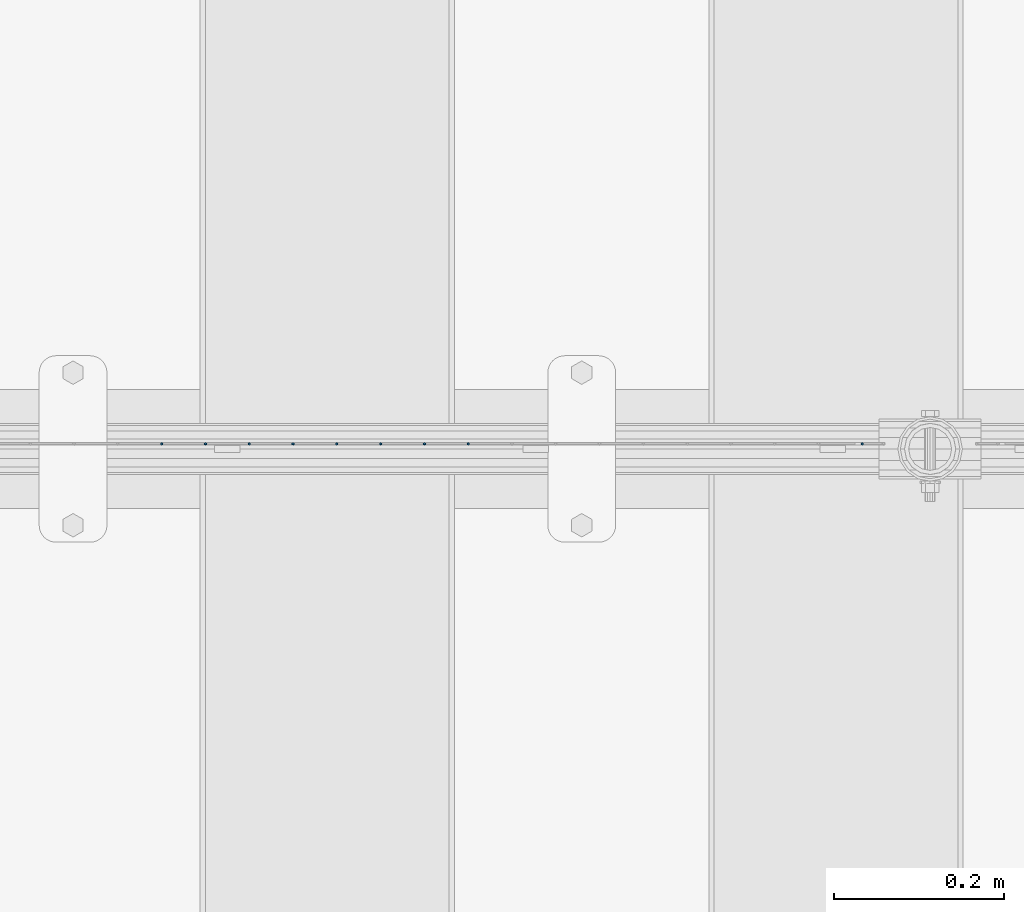
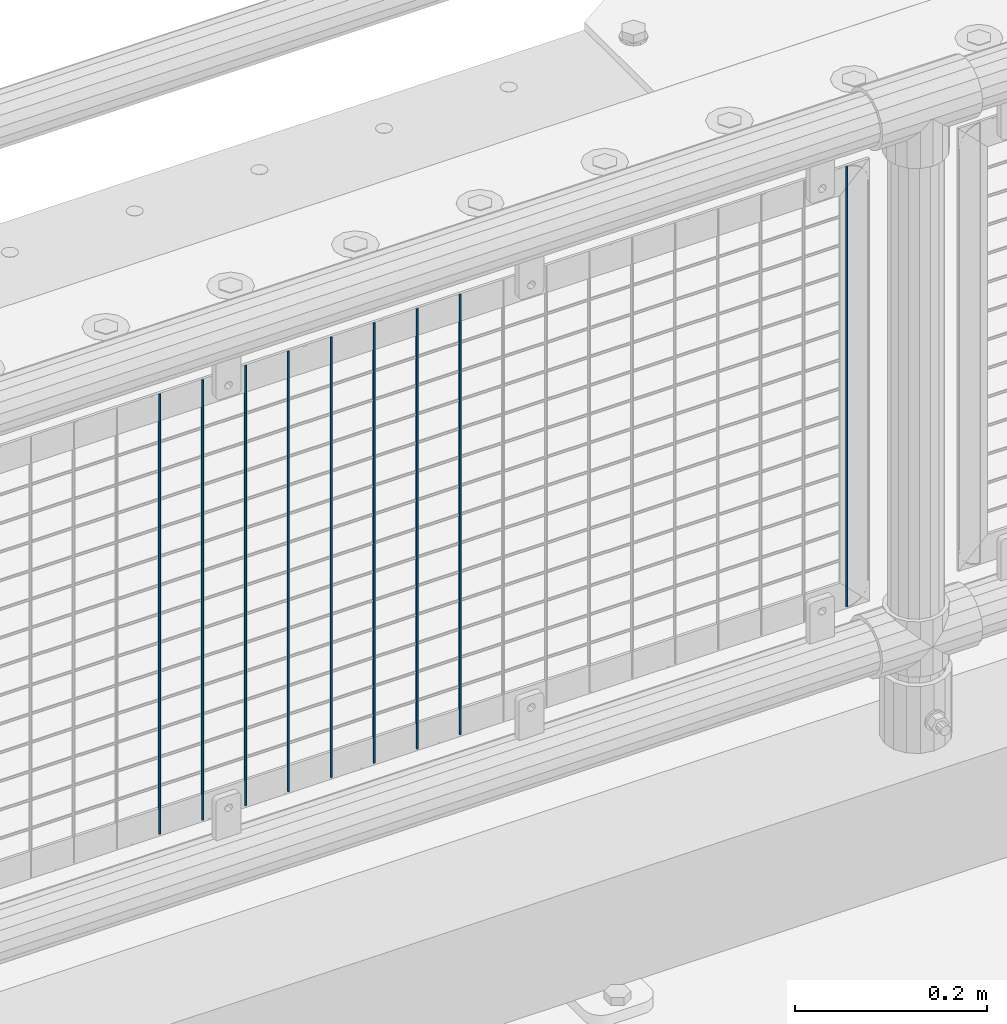
# One storey, part 71 of 193: 9 columns.
"""IFC2X3 building model written with IfcOpenShell, lengths in millimetres."""

from ifc_helpers import new_model, si_unit, frame, origin_with_axes, place, context, subcontext, project, spatial, faceted_brep, material, type_object, element, save


model = new_model("IFC2X3")

# Units and contexts
model_context = context("Model", 3, precision=1e-05, world=origin_with_axes())
body_context = subcontext(model_context, "Body", "Model", "MODEL_VIEW")
ifc_project = project(units=[si_unit("LENGTHUNIT", "METRE", prefix="MILLI"), si_unit("AREAUNIT", "SQUARE_METRE"), si_unit("VOLUMEUNIT", "CUBIC_METRE"), si_unit("MASSUNIT", "GRAM", prefix="KILO"), si_unit("TIMEUNIT", "SECOND"), si_unit("PLANEANGLEUNIT", "RADIAN"), si_unit("SOLIDANGLEUNIT", "STERADIAN"), si_unit("THERMODYNAMICTEMPERATUREUNIT", "DEGREE_CELSIUS"), si_unit("LUMINOUSINTENSITYUNIT", "LUMEN")], contexts=[model_context])

# Site, building, storey
site_placement = place(None, origin_with_axes())
site = spatial("IfcSite", under=ifc_project, at=site_placement, CompositionType="ELEMENT")
building_placement = place(site_placement, origin_with_axes())
building = spatial("IfcBuilding", under=site, at=building_placement, Name="Standard", CompositionType="ELEMENT")
storey_placement = place(building_placement, origin_with_axes())
storey = spatial("IfcBuildingStorey", under=building, at=storey_placement, Name="Undefined", CompositionType="ELEMENT", Elevation=0.0)

# Columns
ifc_material = material(Name="Misc_Undefined")
column_type = type_object("IfcColumnType", Name="D3", PredefinedType="NOTDEFINED")
for number, where, z_axis, x_axis in (
    (1, (-34083.9, 28670.5, 353.020000000001), (-1.0, 0.0, 0.0), (0.0, 0.0, 1.0)),
    (2, (-34135.555, 28670.5, 353.020000000001), (-1.0, 0.0, 0.0), (0.0, 0.0, 1.0)),
    (3, (-34187.21, 28670.5, 353.020000000001), (-1.0, 0.0, 0.0), (0.0, 0.0, 1.0)),
    (4, (-34238.865, 28670.5, 353.020000000001), (-1.0, 0.0, 0.0), (0.0, 0.0, 1.0)),
    (5, (-34290.52, 28670.5, 353.020000000001), (-1.0, 0.0, 0.0), (0.0, 0.0, 1.0)),
    (6, (-34342.175, 28670.5, 353.020000000001), (-1.0, 0.0, 0.0), (0.0, 0.0, 1.0)),
    (7, (-34393.83, 28670.5, 353.020000000001), (-1.0, 0.0, 0.0), (0.0, 0.0, 1.0)),
    (8, (-34445.485, 28670.5, 353.020000000001), (-1.0, 0.0, 0.0), (0.0, 0.0, 1.0)),
    (9, (-33619.005, 28670.5, 353.020000000001), (-1.0, 0.0, 0.0), (0.0, 0.0, 1.0)),
):
    element("IfcColumn", number, at=place(storey_placement, frame(where, z_axis=z_axis, x_axis=x_axis)), inside=storey, type_object=column_type, material=ifc_material, ObjectType="D3", context=body_context, shape_type="Brep", body=[
        faceted_brep([(0.0, -1.49999999999636, 3.63797880709171e-12), (0.0, -0.75, -1.29903810567669), (560.0, -0.75, -1.29903810567703), (560.0, -1.5, 0.0), (0.0, 0.75, -1.29903810567669), (560.0, 0.75, -1.29903810567703), (0.0, 1.50000000000364, 7.27595761418343e-12), (560.0, 1.5, 0.0), (0.0, 0.75, 1.29903810567669), (560.0, 0.75, 1.29903810567703), (0.0, -0.75, 1.29903810567669), (560.0, -0.75, 1.29903810567703)], [[[0, 1, 2, 3]], [[1, 4, 5, 2]], [[4, 6, 7, 5]], [[6, 8, 9, 7]], [[8, 10, 11, 9]], [[10, 0, 3, 11]], [[5, 7, 9, 11, 3, 2]], [[10, 8, 6, 4, 1, 0]]]),
    ])

save(model, "model.ifc")
